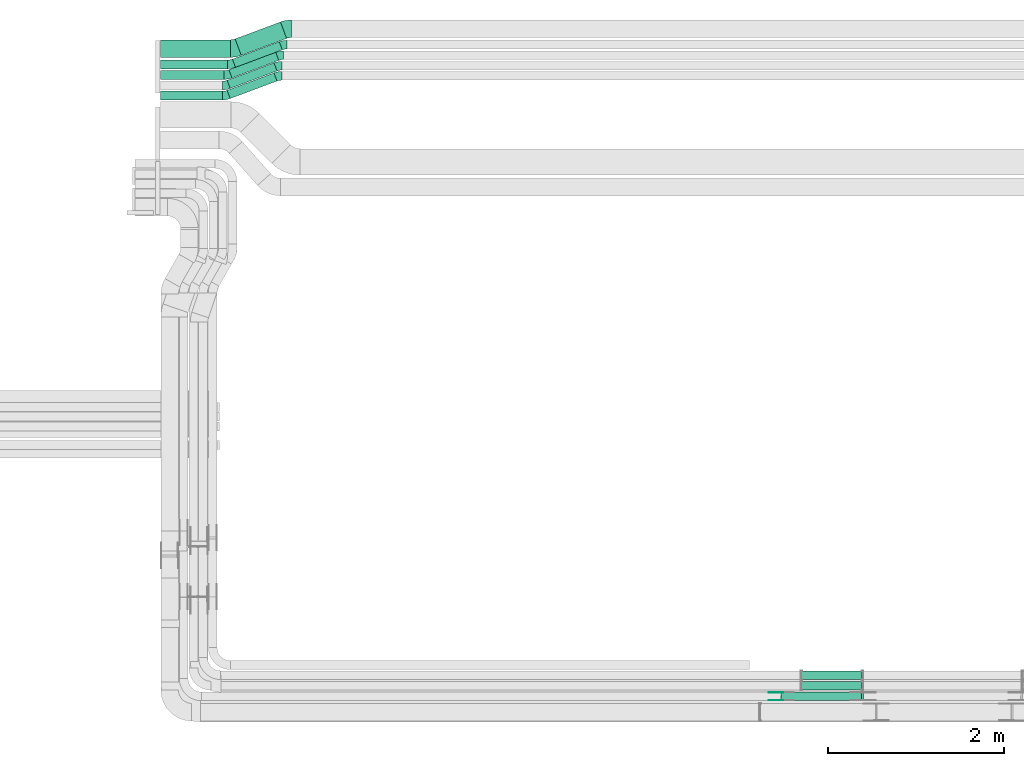
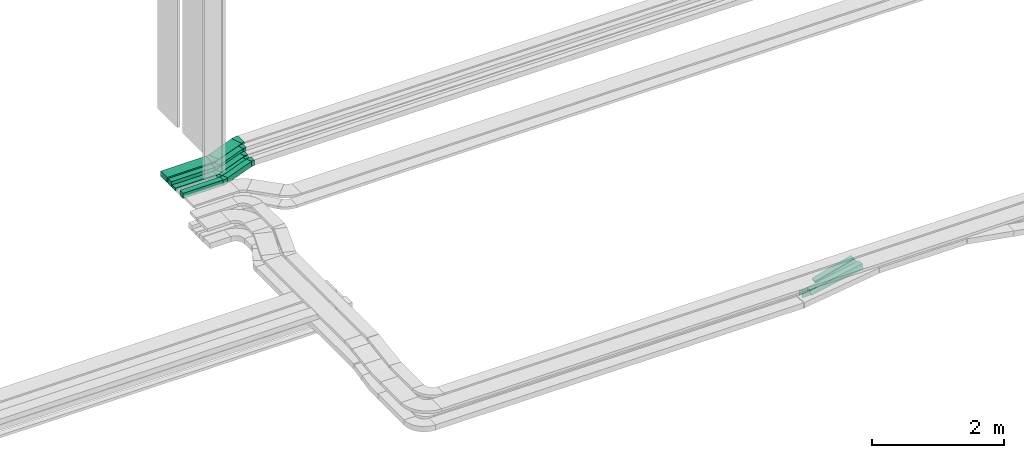
# One storey, part 7 of 28: 12 flow fittings, 12 flow segments.
"""IFC2X3 building model written with IfcOpenShell, lengths in millimetres."""

from ifc_helpers import new_model, entity, si_unit, converted_unit, derived_unit, direction, frame, frame_2d, origin, origin_2d_with_axis, place, context, subcontext, project, spatial, polyline, circle_curve, parameter, trimmed, segment, composite_curve, rectangle, outline, extrude, source, transform, mapped, material, type_object, type_shapes, element, save


model = new_model("IFC2X3")

# Units and contexts
model_context = context("Model", 3, precision=0.01, world=origin(), true_north=direction((6.12303176911189e-17, 1.0)))
body_context = subcontext(model_context, "Body", "Model", "MODEL_VIEW")
ifc_project = project(units=[si_unit("LENGTHUNIT", "METRE", prefix="MILLI"), si_unit("AREAUNIT", "SQUARE_METRE"), si_unit("VOLUMEUNIT", "CUBIC_METRE"), converted_unit("PLANEANGLEUNIT", "DEGREE", entity("IfcRatioMeasure", 0.0174532925199433), si_unit("PLANEANGLEUNIT", "RADIAN"), dimensions=[0, 0, 0, 0, 0, 0, 0]), si_unit("MASSUNIT", "GRAM", prefix="KILO"), derived_unit("MASSDENSITYUNIT", [(si_unit("MASSUNIT", "GRAM", prefix="KILO"), 1), (si_unit("LENGTHUNIT", "METRE"), -3)]), derived_unit("MOMENTOFINERTIAUNIT", [(si_unit("LENGTHUNIT", "METRE"), 4)]), si_unit("TIMEUNIT", "SECOND"), si_unit("FREQUENCYUNIT", "HERTZ"), si_unit("THERMODYNAMICTEMPERATUREUNIT", "DEGREE_CELSIUS"), derived_unit("THERMALTRANSMITTANCEUNIT", [(si_unit("MASSUNIT", "GRAM", prefix="KILO"), 1), (si_unit("THERMODYNAMICTEMPERATUREUNIT", "KELVIN"), -1), (si_unit("TIMEUNIT", "SECOND"), -3)]), derived_unit("VOLUMETRICFLOWRATEUNIT", [(si_unit("LENGTHUNIT", "METRE"), 3), (si_unit("TIMEUNIT", "SECOND"), -1)]), derived_unit("MASSFLOWRATEUNIT", [(si_unit("MASSUNIT", "GRAM", prefix="KILO"), 1), (si_unit("TIMEUNIT", "SECOND"), -1)]), derived_unit("ROTATIONALFREQUENCYUNIT", [(si_unit("TIMEUNIT", "SECOND"), -1)]), si_unit("ELECTRICCURRENTUNIT", "AMPERE"), si_unit("ELECTRICVOLTAGEUNIT", "VOLT"), si_unit("POWERUNIT", "WATT"), si_unit("FORCEUNIT", "NEWTON", prefix="KILO"), si_unit("ILLUMINANCEUNIT", "LUX"), si_unit("LUMINOUSFLUXUNIT", "LUMEN"), si_unit("LUMINOUSINTENSITYUNIT", "CANDELA"), derived_unit("USERDEFINED", [(si_unit("MASSUNIT", "GRAM", prefix="KILO"), -1), (si_unit("LENGTHUNIT", "METRE"), -2), (si_unit("TIMEUNIT", "SECOND"), 3), (si_unit("LUMINOUSFLUXUNIT", "LUMEN"), 1)]), derived_unit("LINEARVELOCITYUNIT", [(si_unit("LENGTHUNIT", "METRE"), 1), (si_unit("TIMEUNIT", "SECOND"), -1)]), si_unit("PRESSUREUNIT", "PASCAL"), derived_unit("USERDEFINED", [(si_unit("LENGTHUNIT", "METRE"), -2), (si_unit("MASSUNIT", "GRAM", prefix="KILO"), 1), (si_unit("TIMEUNIT", "SECOND"), -2)]), derived_unit("LINEARFORCEUNIT", [(si_unit("MASSUNIT", "GRAM", prefix="KILO"), 1), (si_unit("LENGTHUNIT", "METRE"), 1), (si_unit("TIMEUNIT", "SECOND"), -2), (si_unit("LENGTHUNIT", "METRE"), -1)]), derived_unit("PLANARFORCEUNIT", [(si_unit("MASSUNIT", "GRAM", prefix="KILO"), 1), (si_unit("LENGTHUNIT", "METRE"), 1), (si_unit("TIMEUNIT", "SECOND"), -2), (si_unit("LENGTHUNIT", "METRE"), -2)])], contexts=[model_context])

# Site, building, storey
site_placement = place(None, origin())
site = spatial("IfcSite", under=ifc_project, at=site_placement, CompositionType="ELEMENT")
building_placement = place(site_placement, origin())
building = spatial("IfcBuilding", under=site, at=building_placement, CompositionType="ELEMENT")
storey_placement = place(building_placement, frame((0.0, 0.0, 15900.0)))
storey = spatial("IfcBuildingStorey", under=building, at=storey_placement, CompositionType="ELEMENT", Elevation=15900.0)

# Flow segments
cable_carrier_segment_type = type_object("IfcCableCarrierSegmentType", PredefinedType="CABLETRAYSEGMENT")
flow_segment_1_placement = place(storey_placement, frame((23818.38, 8695.5, 2502.48)))
element("IfcFlowSegment", 1, at=flow_segment_1_placement, inside=storey, type_object=cable_carrier_segment_type, context=body_context, shape_type="SweptSolid", body=[
    extrude(rectangle(XDim=50.0000000000003, YDim=99.9999999999989, at=origin_2d_with_axis()), frame((6.38, 50.0, 24.17), z_axis=(0.966919867770266, 0.0, 0.255080319333208), x_axis=(-0.255080319333208, 0.0, 0.966919867770266)), (0.0, 0.0, 1.0), 712.293238662787),
])
flow_segment_2_placement = place(storey_placement, frame((23587.5, 8454.97, 2502.18)))
element("IfcFlowSegment", 2, at=flow_segment_2_placement, inside=storey, type_object=cable_carrier_segment_type, context=body_context, shape_type="SweptSolid", body=[
    extrude(rectangle(XDim=100.000000000002, YDim=100.000000000001, at=origin_2d_with_axis()), frame((9.73, 50.0, 49.04), z_axis=(0.980873765488559, 0.0, 0.194644949013056), x_axis=(-0.194644949013056, 0.0, 0.980873765488559)), (0.0, 0.0, 1.0), 937.836186864069),
])
flow_segment_3_placement = place(storey_placement, frame((23818.38, 8575.5, 2502.48)))
element("IfcFlowSegment", 3, at=flow_segment_3_placement, inside=storey, type_object=cable_carrier_segment_type, context=body_context, shape_type="SweptSolid", body=[
    extrude(rectangle(XDim=50.0000000000003, YDim=100.000000000001, at=origin_2d_with_axis()), frame((6.38, 50.0, 24.17), z_axis=(0.966919867770266, 0.0, 0.255080319333208), x_axis=(-0.255080319333208, 0.0, 0.966919867770266)), (0.0, 0.0, 1.0), 712.293238662787),
])
flow_segment_4_placement = place(storey_placement, frame((16530.0, 15524.46, 2638.31)))
element("IfcFlowSegment", 4, at=flow_segment_4_placement, inside=storey, type_object=cable_carrier_segment_type, context=body_context, shape_type="SweptSolid", body=[
    extrude(rectangle(XDim=722.872698196632, YDim=99.9999999999989, at=origin_2d_with_axis()), frame((361.44, 50.0, 0.0), z_axis=(0.0, 0.0, 1.0), x_axis=(-1.0, 0.0, 0.0)), (0.0, 0.0, 1.0), 50.0000000000016),
])
flow_segment_5_placement = place(storey_placement, frame((16530.0, 15775.0, 2635.0)))
element("IfcFlowSegment", 5, at=flow_segment_5_placement, inside=storey, type_object=cable_carrier_segment_type, context=body_context, shape_type="SweptSolid", body=[
    extrude(rectangle(XDim=793.840872745794, YDim=199.999999999998, at=origin_2d_with_axis()), frame((396.92, 100.0, 0.0), z_axis=(0.0, 0.0, 1.0), x_axis=(-1.0, 0.0, 0.0)), (0.0, 0.0, 1.0), 99.9999999999989),
])
flow_segment_6_placement = place(storey_placement, frame((16530.0, 15645.0, 2635.0)))
element("IfcFlowSegment", 6, at=flow_segment_6_placement, inside=storey, type_object=cable_carrier_segment_type, context=body_context, shape_type="SweptSolid", body=[
    extrude(rectangle(XDim=762.872698196634, YDim=99.9999999999989, at=origin_2d_with_axis()), frame((381.44, 50.0, 0.0), z_axis=(0.0, 0.0, 1.0), x_axis=(-1.0, 0.0, 0.0)), (0.0, 0.0, 1.0), 99.9999999999968),
])
flow_segment_7_placement = place(storey_placement, frame((16530.0, 15290.0, 2635.0)))
element("IfcFlowSegment", 7, at=flow_segment_7_placement, inside=storey, type_object=cable_carrier_segment_type, context=body_context, shape_type="SweptSolid", body=[
    extrude(rectangle(XDim=702.872698196635, YDim=99.9999999999989, at=origin_2d_with_axis()), frame((351.44, 50.0, 0.0), z_axis=(0.0, 0.0, 1.0), x_axis=(-1.0, 0.0, 0.0)), (0.0, 0.0, 1.0), 99.9999999999989),
])
flow_segment_8_placement = place(storey_placement, frame((17378.26, 15797.47, 2635.0)))
element("IfcFlowSegment", 8, at=flow_segment_8_placement, inside=storey, type_object=cable_carrier_segment_type, context=body_context, shape_type="SweptSolid", body=[
    extrude(rectangle(XDim=550.78362976838, YDim=200.000000000002, at=origin_2d_with_axis()), frame((292.97, 190.03, 0.0), z_axis=(0.0, 0.0, 1.0), x_axis=(-0.936802993017805, -0.349857331312182, 0.0)), (0.0, 0.0, 1.0), 99.9999999999989),
])
flow_segment_9_placement = place(storey_placement, frame((17347.29, 15661.15, 2635.0)))
element("IfcFlowSegment", 9, at=flow_segment_9_placement, inside=storey, type_object=cable_carrier_segment_type, context=body_context, shape_type="SweptSolid", body=[
    extrude(rectangle(XDim=568.84728066999, YDim=100.000000000002, at=origin_2d_with_axis()), frame((283.94, 146.35, 0.0), z_axis=(0.0, 0.0, 1.0), x_axis=(0.936802993017794, 0.349857331312211, 0.0)), (0.0, 0.0, 1.0), 99.9999999999989),
])
flow_segment_10_placement = place(storey_placement, frame((17307.29, 15540.61, 2638.31)))
element("IfcFlowSegment", 10, at=flow_segment_10_placement, inside=storey, type_object=cable_carrier_segment_type, context=body_context, shape_type="SweptSolid", body=[
    extrude(rectangle(XDim=568.847280669995, YDim=100.0, at=origin_2d_with_axis()), frame((283.94, 146.35, 0.0), z_axis=(0.0, 0.0, 1.0), x_axis=(0.936802993017794, 0.349857331312212, 0.0)), (0.0, 0.0, 1.0), 50.0000000000016),
])
flow_segment_11_placement = place(storey_placement, frame((17287.29, 15420.61, 2638.31)))
element("IfcFlowSegment", 11, at=flow_segment_11_placement, inside=storey, type_object=cable_carrier_segment_type, context=body_context, shape_type="SweptSolid", body=[
    extrude(rectangle(XDim=568.847280669995, YDim=100.000000000002, at=origin_2d_with_axis()), frame((283.94, 146.35, 0.0), z_axis=(0.0, 0.0, 1.0), x_axis=(0.936802993017794, 0.349857331312212, 0.0)), (0.0, 0.0, 1.0), 50.0000000000016),
])
flow_segment_12_placement = place(storey_placement, frame((17287.29, 15306.15, 2635.0)))
element("IfcFlowSegment", 12, at=flow_segment_12_placement, inside=storey, type_object=cable_carrier_segment_type, context=body_context, shape_type="SweptSolid", body=[
    extrude(rectangle(XDim=568.847280669993, YDim=99.9999999999975, at=origin_2d_with_axis()), frame((283.94, 146.35, 0.0), z_axis=(0.0, 0.0, 1.0), x_axis=(0.936802993017794, 0.349857331312213, 0.0)), (0.0, 0.0, 1.0), 99.9999999999989),
])

# Flow fittings
ifc_material_1 = material(Name="G")
cable_carrier_fitting_type_1 = type_object("IfcCableCarrierFittingType", PredefinedType="NOTDEFINED", material=ifc_material_1)
shared_shape_1 = source(origin(), body_context, "Body", "SweptSolid", [
    extrude(outline(composite_curve([segment(trimmed(circle_curve(frame_2d((-41.47, 0.0), x_axis=(1.0, 0.0)), 25.0), [parameter(90.0000000000007)], [parameter(270.0)], True, "PARAMETER"), True, "CONTINUOUS"), segment(polyline([(-41.47, -25.0), (-29.97, -25.0)]), True, "CONTINUOUS"), segment(polyline([(-29.97, -25.0), (-28.1, -38.5)]), True, "CONTINUOUS"), segment(polyline([(-28.1, -38.5), (99.53, -38.5)]), True, "CONTINUOUS"), segment(polyline([(99.53, -38.5), (99.53, 38.5)]), True, "CONTINUOUS"), segment(polyline([(99.53, 38.5), (-28.1, 38.5)]), True, "CONTINUOUS"), segment(polyline([(-28.1, 38.5), (-29.97, 25.0)]), True, "CONTINUOUS"), segment(polyline([(-29.97, 25.0), (-41.47, 25.0)]), True, "CONTINUOUS")], self_intersect=False)), frame((41.47, 0.0, 0.0), z_axis=(0.0, 0.0, -1.0), x_axis=(1.0, 0.0, 0.0)), (0.0, 0.0, -1.0), 2.0),
])
type_shapes(cable_carrier_fitting_type_1, [shared_shape_1])
flow_fitting_1_placement = place(storey_placement, frame((23591.05, 8548.43, 2550.0), z_axis=(0.0, 1.0, 0.0), x_axis=(-1.0, 0.0, 0.0)))
element("IfcFlowFitting", 13, at=flow_fitting_1_placement, inside=storey, type_object=cable_carrier_fitting_type_1, material=ifc_material_1, context=body_context, shape_type="MappedRepresentation", body=[
    mapped(shared_shape_1, transform((0.0, 0.0, 0.0), scale=1.0)),
])
cable_carrier_fitting_type_2 = type_object("IfcCableCarrierFittingType", PredefinedType="NOTDEFINED", material=ifc_material_1)
shared_shape_2 = source(origin(), body_context, "Body", "SweptSolid", [
    extrude(outline(composite_curve([segment(trimmed(circle_curve(frame_2d((-41.47, 0.0), x_axis=(1.0, 0.0)), 25.0), [parameter(90.0000000000007)], [parameter(270.0)], True, "PARAMETER"), True, "CONTINUOUS"), segment(polyline([(-41.47, -25.0), (-29.97, -25.0)]), True, "CONTINUOUS"), segment(polyline([(-29.97, -25.0), (-28.1, -38.5)]), True, "CONTINUOUS"), segment(polyline([(-28.1, -38.5), (99.53, -38.5)]), True, "CONTINUOUS"), segment(polyline([(99.53, -38.5), (99.53, 38.5)]), True, "CONTINUOUS"), segment(polyline([(99.53, 38.5), (-28.1, 38.5)]), True, "CONTINUOUS"), segment(polyline([(-28.1, 38.5), (-29.97, 25.0)]), True, "CONTINUOUS"), segment(polyline([(-29.97, 25.0), (-41.47, 25.0)]), True, "CONTINUOUS")], self_intersect=False)), frame((41.47, 0.0, 0.0)), (0.0, 0.0, 1.0), 2.0),
])
type_shapes(cable_carrier_fitting_type_2, [shared_shape_2])
flow_fitting_2_placement = place(storey_placement, frame((23591.05, 8461.51, 2550.0), z_axis=(0.0, -1.0, 0.0), x_axis=(-1.0, 0.0, 0.0)))
element("IfcFlowFitting", 14, at=flow_fitting_2_placement, inside=storey, type_object=cable_carrier_fitting_type_2, material=ifc_material_1, context=body_context, shape_type="MappedRepresentation", body=[
    mapped(shared_shape_2, transform((0.0, 0.0, 0.0), scale=1.0)),
])
ifc_material_2 = material()
cable_carrier_fitting_type_3 = type_object("IfcCableCarrierFittingType", Name="470_DKC_S5_Variable Angle Elbow 0-45:-", PredefinedType="NOTDEFINED", material=ifc_material_2)
shared_shape_3 = source(origin(), body_context, "Body", "SweptSolid", [
    extrude(outline(composite_curve([segment(polyline([(-44.72, -107.99), (-43.72, -107.99)]), True, "CONTINUOUS"), segment(trimmed(circle_curve(frame_2d((-43.72, 242.01), x_axis=(0.0, -1.0)), 350.0), [parameter(0.0)], [parameter(20.4785891112335)], True, "PARAMETER"), True, "CONTINUOUS"), segment(polyline([(78.73, -85.87), (79.67, -85.52)]), True, "CONTINUOUS"), segment(polyline([(79.67, -85.52), (9.7, 101.84)]), True, "CONTINUOUS"), segment(polyline([(9.7, 101.84), (8.76, 101.49)]), True, "CONTINUOUS"), segment(trimmed(circle_curve(frame_2d((-43.72, 242.01), x_axis=(0.0, -1.0)), 150.0), [parameter(0.0)], [parameter(20.4785891112335)], True, "PARAMETER"), False, "CONTINUOUS"), segment(polyline([(-43.72, 92.01), (-44.72, 92.01)]), True, "CONTINUOUS"), segment(polyline([(-44.72, 92.01), (-44.72, -107.99)]), True, "CONTINUOUS")], self_intersect=False)), frame((-1.44, 7.99, -50.0)), (0.0, 0.0, 1.0), 100.0),
])
type_shapes(cable_carrier_fitting_type_3, [shared_shape_3])
flow_fitting_3_placement = place(storey_placement, frame((17972.46, 16099.99, 2685.0), z_axis=(0.0, 0.0, 1.0), x_axis=(-1.0, 0.0, 0.0)))
element("IfcFlowFitting", 15, at=flow_fitting_3_placement, inside=storey, type_object=cable_carrier_fitting_type_3, material=ifc_material_2, Name="470_DKC_S5_Variable Angle Elbow 0-45:-", ObjectType="470_DKC_S5_Variable Angle Elbow 0-45:-", context=body_context, shape_type="MappedRepresentation", body=[
    mapped(shared_shape_3, transform((0.0, 0.0, 0.0), scale=1.0)),
])
flow_fitting_4_placement = place(storey_placement, frame((17370.0, 15875.0, 2685.0)))
element("IfcFlowFitting", 16, at=flow_fitting_4_placement, inside=storey, type_object=cable_carrier_fitting_type_3, material=ifc_material_2, Name="470_DKC_S5_Variable Angle Elbow 0-45:-", ObjectType="470_DKC_S5_Variable Angle Elbow 0-45:-", context=body_context, shape_type="MappedRepresentation", body=[
    mapped(shared_shape_3, transform((0.0, 0.0, 0.0), scale=1.0)),
])
cable_carrier_fitting_type_4 = type_object("IfcCableCarrierFittingType", Name="470_DKC_S5_Variable Angle Elbow 0-45:-", PredefinedType="NOTDEFINED", material=ifc_material_2)
shared_shape_4 = source(origin(), body_context, "Body", "SweptSolid", [
    extrude(outline(composite_curve([segment(polyline([(-35.97, -56.41), (-34.97, -56.41)]), True, "CONTINUOUS"), segment(trimmed(circle_curve(frame_2d((-34.97, 193.59), x_axis=(0.0, -1.0)), 250.0), [parameter(0.0)], [parameter(20.4785891112358)], True, "PARAMETER"), True, "CONTINUOUS"), segment(polyline([(52.49, -40.61), (53.43, -40.26)]), True, "CONTINUOUS"), segment(polyline([(53.43, -40.26), (18.45, 53.42)]), True, "CONTINUOUS"), segment(polyline([(18.45, 53.42), (17.51, 53.07)]), True, "CONTINUOUS"), segment(trimmed(circle_curve(frame_2d((-34.97, 193.59), x_axis=(0.0, -1.0)), 150.0), [parameter(0.0)], [parameter(20.4785891112358)], True, "PARAMETER"), False, "CONTINUOUS"), segment(polyline([(-34.97, 43.59), (-35.97, 43.59)]), True, "CONTINUOUS"), segment(polyline([(-35.97, 43.59), (-35.97, -56.41)]), True, "CONTINUOUS")], self_intersect=False)), frame((-1.16, 6.41, -50.0)), (0.0, 0.0, 1.0), 100.0),
])
type_shapes(cable_carrier_fitting_type_4, [shared_shape_4])
flow_fitting_5_placement = place(storey_placement, frame((17330.0, 15695.0, 2685.0)))
element("IfcFlowFitting", 17, at=flow_fitting_5_placement, inside=storey, type_object=cable_carrier_fitting_type_4, material=ifc_material_2, Name="470_DKC_S5_Variable Angle Elbow 0-45:-", ObjectType="470_DKC_S5_Variable Angle Elbow 0-45:-", context=body_context, shape_type="MappedRepresentation", body=[
    mapped(shared_shape_4, transform((0.0, 0.0, 0.0), scale=1.0)),
])
flow_fitting_6_placement = place(storey_placement, frame((17932.46, 15919.99, 2685.0), z_axis=(0.0, 0.0, 1.0), x_axis=(-1.0, 0.0, 0.0)))
element("IfcFlowFitting", 18, at=flow_fitting_6_placement, inside=storey, type_object=cable_carrier_fitting_type_4, material=ifc_material_2, Name="470_DKC_S5_Variable Angle Elbow 0-45:-", ObjectType="470_DKC_S5_Variable Angle Elbow 0-45:-", context=body_context, shape_type="MappedRepresentation", body=[
    mapped(shared_shape_4, transform((0.0, 0.0, 0.0), scale=1.0)),
])
flow_fitting_7_placement = place(storey_placement, frame((17270.0, 15340.0, 2685.0)))
element("IfcFlowFitting", 19, at=flow_fitting_7_placement, inside=storey, type_object=cable_carrier_fitting_type_4, material=ifc_material_2, Name="470_DKC_S5_Variable Angle Elbow 0-45:-", ObjectType="470_DKC_S5_Variable Angle Elbow 0-45:-", context=body_context, shape_type="MappedRepresentation", body=[
    mapped(shared_shape_4, transform((0.0, 0.0, 0.0), scale=1.0)),
])
flow_fitting_8_placement = place(storey_placement, frame((17872.46, 15564.99, 2685.0), z_axis=(0.0, 0.0, 1.0), x_axis=(-1.0, 0.0, 0.0)))
element("IfcFlowFitting", 20, at=flow_fitting_8_placement, inside=storey, type_object=cable_carrier_fitting_type_4, material=ifc_material_2, Name="470_DKC_S5_Variable Angle Elbow 0-45:-", ObjectType="470_DKC_S5_Variable Angle Elbow 0-45:-", context=body_context, shape_type="MappedRepresentation", body=[
    mapped(shared_shape_4, transform((0.0, 0.0, 0.0), scale=1.0)),
])
cable_carrier_fitting_type_5 = type_object("IfcCableCarrierFittingType", Name="470_DKC_S5_Variable Angle Elbow 0-45:-", PredefinedType="NOTDEFINED", material=ifc_material_2)
shared_shape_5 = source(origin(), body_context, "Body", "SweptSolid", [
    extrude(outline(composite_curve([segment(polyline([(-35.97, -56.41), (-34.97, -56.41)]), True, "CONTINUOUS"), segment(trimmed(circle_curve(frame_2d((-34.97, 193.59), x_axis=(0.0, -1.0)), 250.0), [parameter(0.0)], [parameter(20.4785891112358)], True, "PARAMETER"), True, "CONTINUOUS"), segment(polyline([(52.49, -40.61), (53.43, -40.26)]), True, "CONTINUOUS"), segment(polyline([(53.43, -40.26), (18.45, 53.42)]), True, "CONTINUOUS"), segment(polyline([(18.45, 53.42), (17.51, 53.07)]), True, "CONTINUOUS"), segment(trimmed(circle_curve(frame_2d((-34.97, 193.59), x_axis=(0.0, -1.0)), 150.0), [parameter(0.0)], [parameter(20.4785891112358)], True, "PARAMETER"), False, "CONTINUOUS"), segment(polyline([(-34.97, 43.59), (-35.97, 43.59)]), True, "CONTINUOUS"), segment(polyline([(-35.97, 43.59), (-35.97, -56.41)]), True, "CONTINUOUS")], self_intersect=False)), frame((-1.16, 6.41, -25.0)), (0.0, 0.0, 1.0), 50.0000000000001),
])
type_shapes(cable_carrier_fitting_type_5, [shared_shape_5])
flow_fitting_9_placement = place(storey_placement, frame((17290.0, 15574.46, 2663.31)))
element("IfcFlowFitting", 21, at=flow_fitting_9_placement, inside=storey, type_object=cable_carrier_fitting_type_5, material=ifc_material_2, Name="470_DKC_S5_Variable Angle Elbow 0-45:-", ObjectType="470_DKC_S5_Variable Angle Elbow 0-45:-", context=body_context, shape_type="MappedRepresentation", body=[
    mapped(shared_shape_5, transform((0.0, 0.0, 0.0), scale=1.0)),
])
flow_fitting_10_placement = place(storey_placement, frame((17892.46, 15799.46, 2663.31), z_axis=(0.0, 0.0, 1.0), x_axis=(-1.0, 0.0, 0.0)))
element("IfcFlowFitting", 22, at=flow_fitting_10_placement, inside=storey, type_object=cable_carrier_fitting_type_5, material=ifc_material_2, Name="470_DKC_S5_Variable Angle Elbow 0-45:-", ObjectType="470_DKC_S5_Variable Angle Elbow 0-45:-", context=body_context, shape_type="MappedRepresentation", body=[
    mapped(shared_shape_5, transform((0.0, 0.0, 0.0), scale=1.0)),
])
flow_fitting_11_placement = place(storey_placement, frame((17270.0, 15454.46, 2663.31)))
element("IfcFlowFitting", 23, at=flow_fitting_11_placement, inside=storey, type_object=cable_carrier_fitting_type_5, material=ifc_material_2, Name="470_DKC_S5_Variable Angle Elbow 0-45:-", ObjectType="470_DKC_S5_Variable Angle Elbow 0-45:-", context=body_context, shape_type="MappedRepresentation", body=[
    mapped(shared_shape_5, transform((0.0, 0.0, 0.0), scale=1.0)),
])
flow_fitting_12_placement = place(storey_placement, frame((17872.46, 15679.46, 2663.31), z_axis=(0.0, 0.0, 1.0), x_axis=(-1.0, 0.0, 0.0)))
element("IfcFlowFitting", 24, at=flow_fitting_12_placement, inside=storey, type_object=cable_carrier_fitting_type_5, material=ifc_material_2, Name="470_DKC_S5_Variable Angle Elbow 0-45:-", ObjectType="470_DKC_S5_Variable Angle Elbow 0-45:-", context=body_context, shape_type="MappedRepresentation", body=[
    mapped(shared_shape_5, transform((0.0, 0.0, 0.0), scale=1.0)),
])

save(model, "model.ifc")
